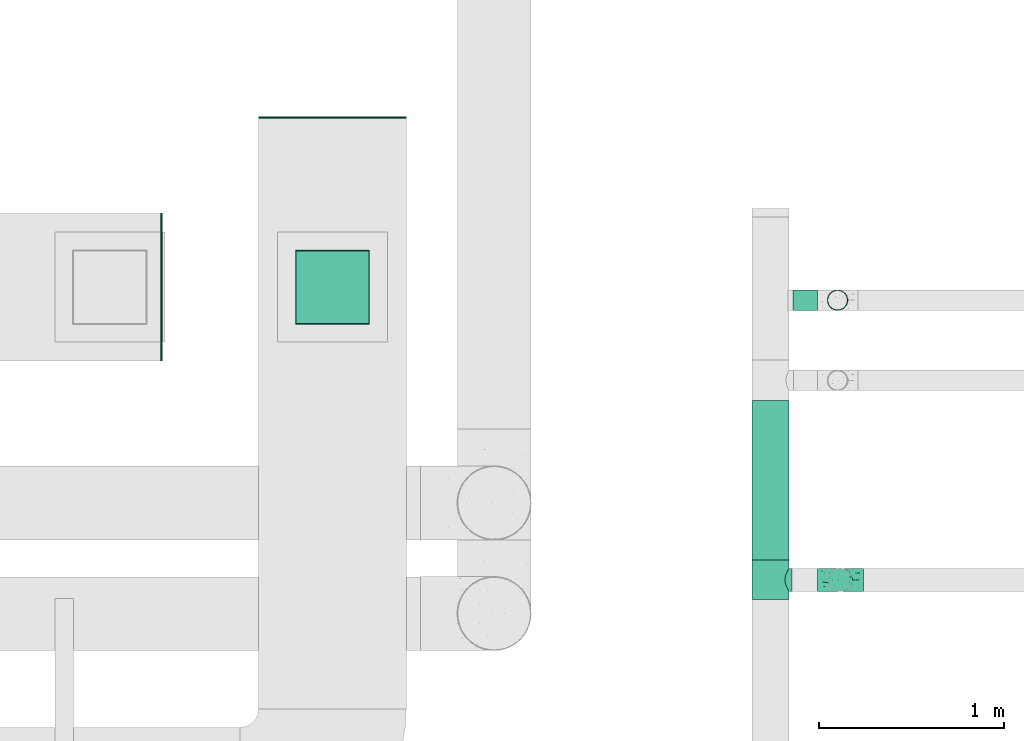
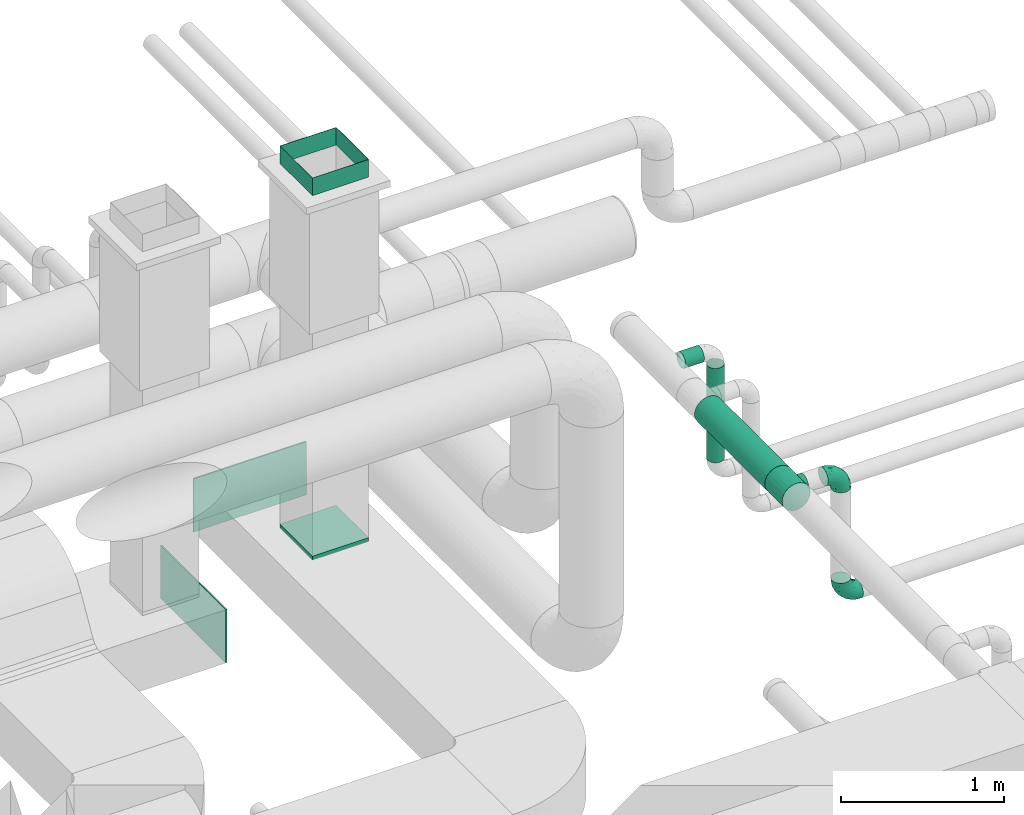
# One storey, part 65 of 91: 6 flow fittings, 4 flow segments.
"""IFC2X3 building model written with IfcOpenShell, lengths in millimetres."""

from ifc_helpers import new_model, entity, si_unit, converted_unit, derived_unit, direction, frame, origin_with_axes, origin_2d_with_axis, place, context, subcontext, project, spatial, hollow_rectangle, hollow_circle, extrude, open_shell, surface_model, source, transform, mapped, material, layer, layer_set, layer_usage, type_object, element, save


model = new_model("IFC2X3")

# Units and contexts
model_context = context("Model", 3, precision=1e-05, world=origin_with_axes(), true_north=direction((0.0, 1.0)))
body_context = subcontext(model_context, "Body", "Model", "MODEL_VIEW")
ifc_project = project(units=[si_unit("AREAUNIT", "SQUARE_METRE"), si_unit("VOLUMEUNIT", "CUBIC_METRE", prefix="DECI"), si_unit("TIMEUNIT", "SECOND"), si_unit("THERMODYNAMICTEMPERATUREUNIT", "DEGREE_CELSIUS"), si_unit("PRESSUREUNIT", "PASCAL"), si_unit("MASSUNIT", "GRAM", prefix="KILO"), si_unit("LENGTHUNIT", "METRE", prefix="MILLI"), si_unit("POWERUNIT", "WATT"), si_unit("ELECTRICCURRENTUNIT", "AMPERE"), si_unit("ELECTRICVOLTAGEUNIT", "VOLT"), derived_unit("VOLUMETRICFLOWRATEUNIT", [(si_unit("VOLUMEUNIT", "CUBIC_METRE", prefix="DECI"), 1), (si_unit("TIMEUNIT", "SECOND"), -1)]), derived_unit("LINEARVELOCITYUNIT", [(si_unit("LENGTHUNIT", "METRE"), 1), (si_unit("TIMEUNIT", "SECOND"), -1)]), derived_unit("MASSDENSITYUNIT", [(si_unit("MASSUNIT", "GRAM", prefix="KILO"), 1), (si_unit("VOLUMEUNIT", "CUBIC_METRE"), -1)]), converted_unit("PLANEANGLEUNIT", "DEGREE", entity("IfcRatioMeasure", 0.01745), si_unit("PLANEANGLEUNIT", "RADIAN"), dimensions=[0, 0, 0, 0, 0, 0, 0])], contexts=[model_context])

# Site, building, storey
site_placement = place(None, origin_with_axes())
site = spatial("IfcSite", under=ifc_project, at=site_placement, CompositionType="ELEMENT")
building_placement = place(site_placement, origin_with_axes())
building = spatial("IfcBuilding", under=site, at=building_placement, Name="mc-building", CompositionType="ELEMENT")
storey_placement = place(building_placement, frame((0.0, 0.0, 8700.0), z_axis=(0.0, 0.0, 1.0), x_axis=(1.0, 0.0, 0.0)))
storey = spatial("IfcBuildingStorey", under=building, at=storey_placement, CompositionType="ELEMENT", Elevation=8700.0)

# Flow fittings
duct_fitting_type_1 = type_object("IfcDuctFittingType", PredefinedType="JUNCTION")
shared_shape_1 = source(origin_with_axes(), body_context, "Body", "SurfaceModel", [
    surface_model("IfcShellBasedSurfaceModel", [(0.0, -115.0, -62.5), (16.17619, -115.0, -60.37037), (-16.17619, -115.0, -60.37037), (-60.37037, -115.0, 16.17619), (-31.25, -115.0, -54.12659), (-44.19417, -115.0, -44.19417), (-54.12659, -115.0, -31.25), (62.5, -115.0, 0.0), (60.37037, -115.0, 16.17619), (44.19417, -115.0, -44.19417), (31.25, -115.0, -54.12659), (60.37037, -115.0, -16.17619), (54.12659, -115.0, -31.25), (-60.37037, -115.0, -16.17619), (-54.12659, -115.0, 31.25), (-44.19417, -115.0, 44.19417), (-31.25, -115.0, 54.12659), (-16.17619, -115.0, 60.37037), (16.17619, -115.0, 60.37037), (54.12659, -115.0, 31.25), (44.19417, -115.0, 44.19417), (31.25, -115.0, 54.12659), (0.0, -115.0, 62.5), (-62.5, -115.0, 0.0), (0.0, -78.06248, 62.5), (-12.50928, -79.05841, 61.23535), (-24.28343, -81.75228, 57.58963), (-34.88436, -85.50245, 51.85876), (-44.09526, -89.65568, 44.29287), (-51.73336, -93.64876, 35.07007), (-57.55016, -96.98335, 24.37682), (-61.23402, -99.21368, 12.5158), (-62.5, -100.0, 0.0), (-61.23126, -99.21198, -12.5293), (-57.54468, -96.9801, -24.38976), (-51.72588, -93.64463, -35.0811), (-44.08702, -89.65163, -44.30107), (-34.87655, -85.49926, -51.86401), (-24.27625, -81.75015, -57.59265), (-12.50125, -79.05714, -61.23699), (0.0, -78.06248, -62.5), (12.50928, -79.05841, -61.23535), (24.28343, -81.75228, -57.58963), (34.88436, -85.50245, -51.85876), (44.09526, -89.65568, -44.29287), (51.73336, -93.64876, -35.07007), (57.55016, -96.98335, -24.37682), (61.23402, -99.21368, -12.5158), (62.5, -100.0, 0.0), (61.23402, -99.21368, 12.5158), (57.55016, -96.98335, 24.37682), (51.73336, -93.64876, 35.07007), (44.09526, -89.65568, 44.29287), (34.88436, -85.50245, 51.85876), (24.28343, -81.75228, 57.58963), (12.50928, -79.05841, 61.23535), (-107.5, 0.0, -100.0), (-107.5, -25.8819, -96.59259), (-107.5, 25.8819, -96.59259), (-107.5, 96.59259, 25.8819), (-107.5, 50.0, -86.60254), (-107.5, 86.60254, -50.0), (-107.5, 70.71068, -70.71068), (-107.5, -100.0, 0.0), (-107.5, -96.59259, 25.8819), (-107.5, -70.71068, -70.71068), (-107.5, -50.0, -86.60254), (-107.5, -96.59259, -25.8819), (-107.5, -86.60254, -50.0), (-107.5, 96.59259, -25.8819), (-107.5, 86.60254, 50.0), (-107.5, 70.71068, 70.71068), (-107.5, 50.0, 86.60254), (-107.5, 25.8819, 96.59259), (-107.5, 0.0, 100.0), (-107.5, -86.60254, 50.0), (-107.5, -70.71068, 70.71068), (-107.5, -25.8819, 96.59259), (-107.5, -50.0, 86.60254), (-107.5, 100.0, 0.0), (107.5, 25.8819, -96.59259), (107.5, 100.0, 0.0), (107.5, 0.0, -100.0), (107.5, 50.0, -86.60254), (107.5, 70.71068, -70.71068), (107.5, 86.60254, -50.0), (107.5, -70.71068, -70.71068), (107.5, -96.59259, 25.8819), (107.5, -50.0, -86.60254), (107.5, -25.8819, -96.59259), (107.5, -86.60254, -50.0), (107.5, -96.59259, -25.8819), (107.5, -100.0, 0.0), (107.5, 96.59259, -25.8819), (107.5, 96.59259, 25.8819), (107.5, 86.60254, 50.0), (107.5, 70.71068, 70.71068), (107.5, 25.8819, 96.59259), (107.5, 50.0, 86.60254), (107.5, -25.8819, 96.59259), (107.5, -86.60254, 50.0), (107.5, -70.71068, 70.71068), (107.5, -50.0, 86.60254), (107.5, 0.0, 100.0), (107.5, -91.59756, -37.94095), (-107.5, -98.29629, -12.94095), (-107.5, -91.59756, -37.94095), (107.5, -98.29629, -12.94095), (107.5, -98.29629, 12.94095), (107.5, -91.59756, 37.94095), (-107.5, -98.29629, 12.94095), (-107.5, -91.59756, 37.94095)], [open_shell([[[0, 1, 2]], [[2, 3, 4]], [[5, 3, 6]], [[4, 3, 5]], [[2, 7, 8]], [[9, 7, 10]], [[1, 10, 7]], [[11, 7, 12]], [[9, 12, 7]], [[7, 2, 1]], [[13, 6, 3]], [[2, 14, 3]], [[2, 15, 14]], [[16, 2, 17]], [[16, 15, 2]], [[17, 2, 18]], [[19, 20, 2]], [[19, 2, 8]], [[20, 21, 2]], [[2, 21, 18]], [[18, 22, 17]], [[23, 13, 3]], [[22, 24, 25]], [[17, 25, 26]], [[16, 26, 27]], [[22, 25, 17]], [[15, 27, 28]], [[16, 17, 26]], [[27, 15, 16]], [[29, 30, 14]], [[31, 32, 23]], [[30, 31, 3]], [[15, 29, 14]], [[3, 14, 30]], [[23, 3, 31]], [[29, 15, 28]], [[32, 33, 23]], [[34, 35, 6]], [[33, 34, 13]], [[23, 33, 13]], [[6, 13, 34]], [[5, 6, 35]], [[35, 36, 5]], [[4, 37, 38]], [[38, 39, 2]], [[40, 0, 39]], [[37, 5, 36]], [[37, 4, 5]], [[4, 38, 2]], [[39, 0, 2]], [[0, 40, 41]], [[1, 41, 42]], [[10, 42, 43]], [[0, 41, 1]], [[9, 43, 44]], [[10, 1, 42]], [[43, 9, 10]], [[45, 46, 12]], [[47, 48, 7]], [[46, 47, 11]], [[9, 45, 12]], [[11, 12, 46]], [[7, 11, 47]], [[45, 9, 44]], [[48, 49, 7]], [[50, 51, 19]], [[49, 50, 8]], [[7, 49, 8]], [[19, 8, 50]], [[20, 19, 51]], [[51, 52, 20]], [[21, 53, 54]], [[54, 55, 18]], [[24, 22, 55]], [[53, 20, 52]], [[53, 21, 20]], [[21, 54, 18]], [[55, 22, 18]], [[56, 57, 58]], [[58, 59, 60]], [[61, 62, 59]], [[59, 62, 60]], [[58, 63, 64]], [[65, 63, 66]], [[58, 57, 66]], [[67, 63, 68]], [[65, 68, 63]], [[66, 63, 58]], [[69, 61, 59]], [[70, 59, 58]], [[58, 71, 70]], [[72, 58, 73]], [[72, 71, 58]], [[74, 73, 58]], [[75, 76, 58]], [[58, 64, 75]], [[77, 74, 78]], [[58, 76, 78]], [[78, 74, 58]], [[79, 69, 59]], [[80, 81, 82]], [[83, 81, 80]], [[81, 84, 85]], [[83, 84, 81]], [[86, 82, 87]], [[82, 88, 89]], [[82, 86, 88]], [[90, 87, 91]], [[87, 90, 86]], [[92, 91, 87]], [[93, 81, 85]], [[94, 95, 82]], [[95, 96, 82]], [[97, 82, 98]], [[82, 96, 98]], [[99, 82, 97]], [[82, 100, 87]], [[101, 100, 82]], [[101, 82, 102]], [[99, 102, 82]], [[97, 103, 99]], [[82, 81, 94]], [[73, 103, 97]], [[72, 97, 98]], [[74, 103, 73]], [[73, 97, 72]], [[98, 71, 72]], [[98, 96, 71]], [[59, 95, 94]], [[79, 94, 81]], [[96, 70, 71]], [[96, 95, 70]], [[70, 95, 59]], [[94, 79, 59]], [[93, 85, 61]], [[81, 93, 69]], [[69, 79, 81]], [[61, 69, 93]], [[85, 62, 61]], [[85, 84, 62]], [[58, 83, 80]], [[56, 80, 82]], [[84, 60, 62]], [[84, 83, 60]], [[60, 83, 58]], [[80, 56, 58]], [[89, 57, 82]], [[88, 66, 89]], [[42, 90, 43]], [[90, 42, 86]], [[44, 104, 45]], [[42, 41, 86]], [[88, 86, 65]], [[86, 41, 40]], [[57, 89, 66]], [[65, 66, 88]], [[57, 56, 82]], [[40, 39, 65]], [[33, 63, 105]], [[65, 38, 68]], [[35, 67, 106]], [[46, 107, 47]], [[39, 38, 65]], [[65, 86, 40]], [[68, 38, 37]], [[104, 91, 45]], [[44, 90, 104]], [[91, 46, 45]], [[92, 48, 47]], [[91, 107, 46]], [[47, 107, 92]], [[35, 106, 36]], [[68, 36, 106]], [[35, 34, 67]], [[68, 37, 36]], [[105, 67, 34]], [[32, 63, 33]], [[105, 34, 33]], [[43, 90, 44]], [[48, 92, 49]], [[108, 87, 50]], [[50, 87, 51]], [[50, 49, 108]], [[52, 51, 109]], [[109, 100, 52]], [[63, 31, 110]], [[63, 32, 31]], [[30, 64, 110]], [[28, 75, 111]], [[111, 64, 29]], [[75, 28, 27]], [[29, 64, 30]], [[53, 100, 54]], [[51, 87, 109]], [[101, 55, 54]], [[54, 100, 101]], [[30, 110, 31]], [[102, 99, 77]], [[78, 101, 102]], [[55, 101, 24]], [[74, 99, 103]], [[25, 24, 76]], [[49, 92, 108]], [[26, 76, 75]], [[25, 76, 26]], [[28, 111, 29]], [[24, 101, 76]], [[101, 78, 76]], [[77, 78, 102]], [[99, 74, 77]], [[26, 75, 27]], [[53, 52, 100]]])]),
])
flow_fitting_1_placement = place(storey_placement, frame((33364.76981, 6304.03427, 1344.0), z_axis=(0.0, 0.0, 1.0), x_axis=(0.0, 1.0, 0.0)))
element("IfcFlowFitting", 1, at=flow_fitting_1_placement, inside=storey, type_object=duct_fitting_type_1, context=body_context, shape_type="MappedRepresentation", body=[
    mapped(shared_shape_1, transform((0.0, 0.0, 0.0), scale=1.0)),
])
duct_fitting_type_2 = type_object("IfcDuctFittingType", Name="BU", PredefinedType="BEND")
shared_shape_2 = source(origin_with_axes(), body_context, "Body", "SurfaceModel", [
    surface_model("IfcShellBasedSurfaceModel", [(-125.0, 0.0, -62.5), (-125.0, -16.17619, -60.37037), (-125.0, 16.17619, -60.37037), (-125.0, 60.37037, 16.17619), (-125.0, 31.25, -54.12659), (-125.0, 54.12659, -31.25), (-125.0, 44.19417, -44.19417), (-125.0, -62.5, 0.0), (-125.0, -60.37037, 16.17619), (-125.0, -44.19417, -44.19417), (-125.0, -31.25, -54.12659), (-125.0, -60.37037, -16.17619), (-125.0, -54.12659, -31.25), (-125.0, 60.37037, -16.17619), (-125.0, 54.12659, 31.25), (-125.0, 44.19417, 44.19417), (-125.0, 16.17619, 60.37037), (-125.0, 31.25, 54.12659), (-125.0, -16.17619, 60.37037), (-125.0, -54.12659, 31.25), (-125.0, -44.19417, 44.19417), (-125.0, -31.25, 54.12659), (-125.0, 0.0, 62.5), (-125.0, 62.5, 0.0), (-16.17619, 125.0, -60.37037), (-62.5, 125.0, 0.0), (0.0, 125.0, -62.5), (-31.25, 125.0, -54.12659), (-44.19417, 125.0, -44.19417), (-54.12659, 125.0, -31.25), (44.19417, 125.0, -44.19417), (60.37037, 125.0, 16.17619), (31.25, 125.0, -54.12659), (16.17619, 125.0, -60.37037), (54.12659, 125.0, -31.25), (60.37037, 125.0, -16.17619), (62.5, 125.0, 0.0), (-60.37037, 125.0, -16.17619), (-60.37037, 125.0, 16.17619), (-54.12659, 125.0, 31.25), (-44.19417, 125.0, 44.19417), (-31.25, 125.0, 54.12659), (0.0, 125.0, 62.5), (-16.17619, 125.0, 60.37037), (54.12659, 125.0, 31.25), (44.19417, 125.0, 44.19417), (31.25, 125.0, 54.12659), (16.17619, 125.0, 60.37037), (-72.97423, 55.32904, 49.58459), (-87.09148, 43.38651, 51.77259), (-68.69218, 37.01083, 59.02974), (-86.37288, 6.11794, 62.5), (-102.44946, 13.57266, 61.46748), (-89.31796, 30.42505, 57.74247), (-79.75876, 21.08139, 61.40263), (-85.85709, 61.60432, 36.83247), (-105.99571, 52.01835, 38.04759), (-109.23107, 25.15527, 57.74247), (-23.87288, 51.52684, 62.5), (-20.86657, 80.09577, 61.41459), (-36.41116, 67.77294, 59.36871), (-72.59833, 84.97566, 20.44471), (-84.84527, 71.68644, 22.63776), (-72.28039, 75.08953, 34.06229), (-113.17841, 59.9112, 21.05599), (-105.80839, 64.31191, 11.93589), (-111.60883, 65.16367, 0.0), (-60.71426, 105.22832, 23.91771), (-100.62332, 62.31546, 23.91771), (-13.4791, 102.54506, 61.48083), (-6.11794, 86.37288, 62.5), (-65.16367, 111.60883, 0.0), (-64.37068, 105.82697, 11.61464), (-51.52684, 23.87288, 62.5), (-50.69134, 50.69135, 59.24335), (-105.32369, 40.3031, 49.58458), (-25.28712, 108.41778, 57.74247), (-40.88389, 102.97269, 49.58458), (-49.66967, 79.07581, 50.53579), (-30.95126, 87.95323, 57.74247), (-65.09409, 90.12761, 28.38341), (-66.67939, 95.80824, 18.23245), (-94.24179, 68.59274, 14.67936), (-56.68565, 61.95245, 53.66363), (-84.74719, 75.95181, 10.86071), (-51.54332, 107.92365, 38.04759), (-67.25753, 101.08228, 0.0), (-58.54205, 89.35136, 38.04759), (-74.03168, 90.94406, 0.0), (-64.15138, 70.52814, 45.04029), (-101.08228, 67.25753, 0.0), (-80.80582, 80.80582, 0.0), (-90.94406, 74.03168, 0.0), (-107.87602, 51.55441, -38.04759), (-105.81087, 64.31979, -11.89334), (-113.23859, 59.9943, -20.79563), (-102.50484, 41.0078, -49.58458), (-90.90834, 52.91787, -43.09941), (-86.37288, 6.11794, -62.5), (-82.6746, 22.37103, -60.91508), (-51.52684, 23.87288, -62.5), (-24.90859, 74.00088, -61.20337), (-6.11794, 86.37288, -62.5), (-23.87288, 51.52684, -62.5), (-40.24859, 105.55983, -49.58458), (-103.52624, 12.53143, -61.61172), (-52.01835, 105.9957, -38.04759), (-102.84629, 26.37525, -57.74247), (-80.60061, 37.86129, -56.26993), (-89.23788, 71.99576, -13.34087), (-28.31259, 95.51825, -57.74247), (-100.89706, 62.20969, -23.91771), (-79.09001, 65.16893, -38.04759), (-83.36843, 70.98492, -26.07025), (-72.14843, 76.80808, -32.35146), (-64.31191, 105.80839, -11.93589), (-62.31546, 100.62332, -23.91771), (-61.48499, 86.19979, -36.72576), (-65.63586, 35.3365, -60.01002), (-59.9112, 113.17841, -21.05599), (-14.35128, 101.66255, -61.35337), (-39.16846, 75.52412, -56.86737), (-49.98148, 49.98148, -59.57135), (-74.75599, 82.48123, -20.09995), (-79.93714, 49.60562, -50.24944), (-65.30683, 59.08485, -51.03937), (-69.00621, 93.51335, -14.6428), (-48.12403, 84.36987, -49.58459), (-65.05902, 72.16091, -43.27513), (-91.99255, 60.8749, -33.31849), (-74.30538, -22.05025, -54.52849), (-83.27732, -57.79898, 0.0), (-93.43528, -58.70511, -11.68929), (-65.26967, -50.32842, -16.71444), (20.96007, 31.53005, -39.63719), (36.17209, 58.4237, -38.31102), (29.66468, 29.66696, -26.32537), (-59.46467, 5.17337, -61.41841), (9.88584, 35.44281, -50.43749), (-6.21876, 6.21876, -45.37394), (1.26602, -1.26602, -32.1996), (5.97284, -5.97284, -16.71444), (-29.66696, -29.66468, -26.32537), (-5.17337, 59.46467, -61.41841), (-25.56296, 25.56296, -60.51531), (-85.76554, -12.75621, -59.78088), (48.55289, 56.98302, -11.64673), (57.71969, 88.32124, -11.85826), (57.79898, 83.27732, 0.0), (-8.09566, -21.5934, 0.0), (-43.6468, -43.93166, 0.0), (-26.3245, -32.97333, -12.3928), (-83.98915, -46.13442, -36.15679), (-66.40639, -30.82245, -46.75569), (-31.53004, -20.96006, -39.63719), (-52.51367, -36.89027, -34.10077), (12.75621, 85.76554, -59.78088), (4.48155, 49.92421, -57.42403), (37.53998, 99.49287, -48.41169), (22.05025, 74.30538, -54.52849), (-15.22434, 15.22435, -54.69384), (-49.9242, -4.48154, -57.42403), (51.83554, 76.17092, -22.12398), (46.66757, 86.70304, -36.28653), (-35.4428, -9.88583, -50.43749), (21.5934, 8.09566, 0.0), (43.93166, 43.6468, 0.0), (32.97333, 26.3245, -12.3928), (-99.49287, -37.53998, -48.41169), (30.82245, 66.40639, -46.75569), (-56.98302, -48.55289, 11.64673), (-88.32124, -57.71969, 11.85826), (50.32842, 65.26967, 16.71444), (-76.17092, -51.83554, 22.12398), (-5.17337, 59.46467, 61.41841), (12.75621, 85.76554, 59.78088), (-85.76554, -12.75621, 59.78088), (-49.9242, -4.48154, 57.42403), (-59.46467, 5.17337, 61.41841), (-26.3245, -32.97333, 12.3928), (-35.4428, -9.88583, 50.43749), (-31.53004, -20.96006, 39.63719), (-6.21876, 6.21876, 45.37394), (32.97333, 26.3245, 12.3928), (5.97284, -5.97284, 16.71444), (-99.49287, -37.53998, 48.41169), (-86.70304, -46.66757, 36.28653), (9.88584, 35.44281, 50.43749), (20.96007, 31.53005, 39.63719), (-15.22434, 15.22435, 54.69384), (4.48155, 49.92421, 57.42403), (-74.30538, -22.05025, 54.52849), (-25.56296, 25.56296, 60.51531), (37.53998, 99.49287, 48.41169), (46.13442, 83.98915, 36.15679), (29.66468, 29.66696, 26.32537), (-29.66696, -29.66468, 26.32537), (1.26602, -1.26602, 32.1996), (58.70511, 93.43528, 11.68929), (30.82245, 66.40639, 46.75569), (36.89027, 52.51367, 34.10076), (22.05025, 74.30538, 54.52849), (-58.42369, -36.17209, 38.31102), (-66.40639, -30.82245, 46.75569)], [open_shell([[[0, 1, 2]], [[2, 3, 4]], [[5, 6, 3]], [[4, 3, 6]], [[2, 7, 8]], [[9, 7, 10]], [[1, 10, 7]], [[11, 7, 12]], [[9, 12, 7]], [[7, 2, 1]], [[5, 3, 13]], [[14, 3, 2]], [[15, 14, 2]], [[2, 16, 17]], [[17, 15, 2]], [[2, 18, 16]], [[2, 8, 19]], [[2, 19, 20]], [[20, 21, 2]], [[18, 2, 21]], [[18, 22, 16]], [[23, 13, 3]], [[24, 25, 26]], [[27, 25, 24]], [[25, 28, 29]], [[28, 25, 27]], [[30, 26, 31]], [[26, 32, 33]], [[26, 30, 32]], [[30, 31, 34]], [[34, 31, 35]], [[31, 36, 35]], [[29, 37, 25]], [[38, 39, 26]], [[39, 40, 26]], [[26, 41, 42]], [[41, 26, 40]], [[41, 43, 42]], [[44, 31, 26]], [[45, 44, 26]], [[26, 46, 45]], [[47, 46, 26]], [[47, 26, 42]], [[25, 38, 26]], [[48, 49, 50]], [[22, 51, 52]], [[53, 54, 50]], [[55, 56, 49]], [[56, 14, 15]], [[16, 57, 17]], [[58, 59, 60]], [[61, 62, 63]], [[3, 64, 65]], [[53, 52, 54]], [[3, 65, 66]], [[67, 39, 38]], [[56, 68, 64]], [[65, 64, 68]], [[69, 59, 70]], [[38, 71, 72]], [[73, 58, 74]], [[75, 49, 56]], [[76, 69, 43]], [[53, 57, 52]], [[77, 78, 79]], [[41, 76, 43]], [[43, 69, 42]], [[55, 68, 56]], [[15, 17, 75]], [[76, 77, 79]], [[80, 67, 81]], [[62, 82, 68]], [[60, 78, 83]], [[62, 84, 82]], [[85, 77, 40]], [[81, 67, 72]], [[86, 72, 71]], [[87, 85, 67]], [[61, 81, 88]], [[77, 41, 40]], [[78, 77, 87]], [[15, 75, 56]], [[83, 89, 48]], [[85, 40, 39]], [[62, 68, 55]], [[89, 87, 63]], [[83, 48, 50]], [[57, 75, 17]], [[49, 75, 53]], [[67, 85, 39]], [[87, 77, 85]], [[63, 62, 55]], [[89, 55, 48]], [[80, 63, 87]], [[66, 65, 90]], [[66, 23, 3]], [[84, 91, 92]], [[92, 90, 82]], [[65, 82, 90]], [[61, 84, 62]], [[92, 82, 84]], [[68, 82, 65]], [[3, 14, 64]], [[56, 64, 14]], [[38, 25, 71]], [[81, 72, 86]], [[38, 72, 67]], [[91, 61, 88]], [[80, 81, 61]], [[63, 80, 61]], [[67, 80, 87]], [[77, 76, 41]], [[79, 59, 69]], [[79, 69, 76]], [[42, 69, 70]], [[60, 59, 79]], [[58, 70, 59]], [[78, 60, 79]], [[58, 60, 74]], [[52, 57, 16]], [[75, 57, 53]], [[22, 52, 16]], [[52, 51, 54]], [[51, 73, 54]], [[50, 73, 74]], [[73, 50, 54]], [[50, 74, 83]], [[60, 83, 74]], [[89, 83, 78]], [[87, 89, 78]], [[55, 89, 63]], [[50, 49, 53]], [[55, 49, 48]], [[81, 86, 88]], [[91, 84, 61]], [[6, 5, 93]], [[90, 94, 66]], [[13, 94, 95]], [[96, 93, 97]], [[98, 99, 100]], [[96, 4, 6]], [[101, 102, 103]], [[28, 27, 104]], [[2, 105, 0]], [[104, 106, 28]], [[99, 105, 107]], [[108, 107, 96]], [[90, 109, 94]], [[107, 2, 4]], [[13, 66, 94]], [[27, 24, 110]], [[109, 111, 94]], [[112, 113, 114]], [[37, 115, 71]], [[116, 106, 117]], [[99, 118, 100]], [[116, 115, 119]], [[37, 119, 115]], [[24, 120, 110]], [[121, 110, 101]], [[119, 106, 116]], [[101, 110, 120]], [[122, 103, 100]], [[117, 123, 116]], [[124, 125, 108]], [[115, 116, 126]], [[106, 29, 28]], [[26, 102, 120]], [[127, 104, 110]], [[97, 124, 96]], [[125, 122, 118]], [[128, 127, 125]], [[96, 6, 93]], [[115, 126, 86]], [[117, 106, 127]], [[111, 113, 129]], [[95, 93, 5]], [[97, 129, 112]], [[110, 104, 27]], [[106, 104, 127]], [[96, 107, 4]], [[99, 107, 108]], [[99, 108, 118]], [[105, 99, 98]], [[112, 114, 128]], [[121, 125, 127]], [[13, 23, 66]], [[109, 90, 92]], [[94, 111, 95]], [[91, 123, 109]], [[129, 113, 112]], [[93, 95, 111]], [[5, 13, 95]], [[71, 115, 86]], [[71, 25, 37]], [[123, 91, 88]], [[126, 116, 123]], [[123, 88, 126]], [[86, 126, 88]], [[37, 29, 119]], [[106, 119, 29]], [[129, 93, 111]], [[124, 112, 125]], [[0, 105, 98]], [[107, 105, 2]], [[125, 118, 108]], [[100, 118, 122]], [[93, 129, 97]], [[113, 111, 109]], [[109, 123, 113]], [[114, 123, 117]], [[123, 114, 113]], [[128, 114, 117]], [[127, 128, 117]], [[112, 128, 125]], [[103, 122, 101]], [[110, 121, 127]], [[101, 122, 121]], [[125, 121, 122]], [[26, 120, 24]], [[101, 120, 102]], [[96, 124, 108]], [[92, 91, 109]], [[112, 124, 97]], [[10, 1, 130]], [[131, 132, 133]], [[134, 135, 136]], [[98, 100, 137]], [[138, 134, 139]], [[140, 141, 142]], [[143, 144, 103]], [[98, 145, 0]], [[146, 147, 148]], [[149, 150, 151]], [[7, 11, 132]], [[133, 12, 152]], [[153, 154, 155]], [[152, 12, 9]], [[156, 157, 143]], [[142, 151, 133]], [[155, 133, 152]], [[158, 159, 32]], [[136, 141, 140]], [[137, 145, 98]], [[103, 144, 100]], [[133, 132, 12]], [[160, 161, 144]], [[137, 144, 161]], [[160, 144, 157]], [[156, 26, 33]], [[130, 1, 145]], [[34, 162, 163]], [[164, 139, 154]], [[30, 158, 32]], [[160, 138, 139]], [[163, 30, 34]], [[156, 159, 157]], [[149, 141, 165]], [[146, 166, 167]], [[168, 9, 10]], [[36, 148, 147]], [[9, 168, 152]], [[150, 131, 133]], [[166, 146, 148]], [[166, 165, 167]], [[141, 136, 167]], [[160, 164, 161]], [[143, 103, 102]], [[151, 141, 149]], [[35, 162, 34]], [[135, 162, 136]], [[158, 163, 169]], [[144, 137, 100]], [[145, 137, 161]], [[145, 161, 130]], [[145, 1, 0]], [[102, 26, 156]], [[144, 143, 157]], [[102, 156, 143]], [[159, 33, 32]], [[141, 167, 165]], [[146, 136, 162]], [[133, 151, 150]], [[141, 151, 142]], [[164, 130, 161]], [[130, 153, 168]], [[159, 156, 33]], [[138, 159, 169]], [[138, 160, 157]], [[164, 160, 139]], [[154, 140, 142]], [[134, 140, 139]], [[159, 138, 157]], [[134, 136, 140]], [[138, 169, 134]], [[135, 134, 169]], [[139, 140, 154]], [[130, 164, 153]], [[155, 154, 142]], [[153, 164, 154]], [[136, 146, 167]], [[146, 162, 147]], [[162, 35, 147]], [[36, 147, 35]], [[130, 168, 10]], [[152, 168, 153]], [[163, 158, 30]], [[159, 158, 169]], [[7, 132, 131]], [[12, 132, 11]], [[169, 163, 135]], [[135, 163, 162]], [[133, 155, 142]], [[153, 155, 152]], [[150, 170, 131]], [[171, 7, 131]], [[166, 148, 172]], [[8, 173, 19]], [[174, 175, 70]], [[176, 177, 178]], [[149, 179, 150]], [[170, 150, 179]], [[180, 181, 182]], [[165, 183, 184]], [[20, 185, 21]], [[20, 19, 186]], [[187, 182, 188]], [[189, 187, 190]], [[185, 191, 21]], [[22, 18, 176]], [[190, 192, 189]], [[189, 180, 182]], [[178, 73, 51]], [[19, 173, 186]], [[149, 165, 184]], [[45, 193, 194]], [[191, 177, 176]], [[165, 166, 183]], [[195, 183, 172]], [[196, 184, 197]], [[194, 44, 45]], [[198, 36, 31]], [[199, 188, 200]], [[172, 198, 44]], [[193, 45, 46]], [[194, 200, 172]], [[175, 42, 70]], [[192, 58, 73]], [[170, 171, 131]], [[189, 192, 177]], [[70, 58, 174]], [[190, 174, 192]], [[179, 184, 196]], [[197, 184, 195]], [[47, 201, 46]], [[181, 202, 196]], [[148, 198, 172]], [[201, 47, 175]], [[172, 44, 194]], [[178, 192, 73]], [[202, 173, 196]], [[185, 186, 203]], [[192, 174, 58]], [[175, 174, 190]], [[175, 190, 201]], [[175, 47, 42]], [[51, 22, 176]], [[192, 178, 177]], [[51, 176, 178]], [[191, 18, 21]], [[184, 179, 149]], [[170, 196, 173]], [[172, 183, 166]], [[184, 183, 195]], [[187, 201, 190]], [[201, 199, 193]], [[191, 176, 18]], [[180, 191, 203]], [[180, 189, 177]], [[187, 189, 182]], [[188, 197, 195]], [[181, 197, 182]], [[191, 180, 177]], [[181, 196, 197]], [[180, 203, 181]], [[202, 181, 203]], [[182, 197, 188]], [[201, 187, 199]], [[200, 188, 195]], [[199, 187, 188]], [[196, 170, 179]], [[170, 173, 171]], [[173, 8, 171]], [[7, 171, 8]], [[201, 193, 46]], [[194, 193, 199]], [[186, 185, 20]], [[191, 185, 203]], [[36, 198, 148]], [[44, 198, 31]], [[203, 186, 202]], [[202, 186, 173]], [[172, 200, 195]], [[199, 200, 194]]])]),
])
for number, where, z_axis, x_axis, name in (
    (2, (33742.76981, 6304.03427, 1344.0), (0.0, -1.0, 0.0), (0.0, 0.0, 1.0), "BU"),
    (3, (33742.76981, 6304.03427, 415.0), (0.0, 1.0, 0.0), (-1.0, 0.0, 0.0), "BU"),
):
    element("IfcFlowFitting", number, at=place(storey_placement, frame(where, z_axis=z_axis, x_axis=x_axis)), inside=storey, type_object=duct_fitting_type_2, Name=name, context=body_context, shape_type="MappedRepresentation", body=[
        mapped(shared_shape_2, transform((0.0, 0.0, 0.0), scale=1.0)),
    ])

# Flow segment
ifc_material_1 = material(Name="FZ1")
ifc_layer_1 = layer(ifc_material_1, 0.0)
ifc_layer_set_1 = layer_set([ifc_layer_1], Name="FZ1")
ifc_layer_usage_1 = layer_usage(ifc_layer_set_1, "AXIS1", "POSITIVE", 0.0)
duct_segment_type_1 = type_object("IfcDuctSegmentType", PredefinedType="RIGIDSEGMENT")
shared_shape_3 = source(origin_with_axes(), body_context, "Body", "SweptSolid", [
    extrude(hollow_circle(Radius=55.0, WallThickness=2.0, at=origin_2d_with_axis()), frame((0.0, 0.0, 0.0), z_axis=(1.0, 0.0, 0.0), x_axis=(0.0, 1.0, 0.0)), (0.0, 0.0, 1.0), 709.0),
])
flow_segment_1_placement = place(storey_placement, frame((33727.76981, 7819.73852, 1234.0), z_axis=(0.0, 1.0, 0.0), x_axis=(0.0, 0.0, -1.0)))
element("IfcFlowSegment", 4, at=flow_segment_1_placement, inside=storey, type_object=duct_segment_type_1, material=ifc_layer_usage_1, context=body_context, shape_type="MappedRepresentation", body=[
    mapped(shared_shape_3, transform((0.0, 0.0, 0.0), scale=1.0)),
])

# Flow fittings
duct_fitting_type_3 = type_object("IfcDuctFittingType", Name="R", PredefinedType="OBSTRUCTION")
shared_shape_4 = source(origin_with_axes(), body_context, "Body", "SurfaceModel", [
    surface_model("IfcShellBasedSurfaceModel", [(0.0, 400.0, 200.0), (0.0, 400.0, -200.0), (0.0, -400.0, -200.0), (0.0, -400.0, 200.0), (10.0, -400.0, -200.0), (10.0, 400.0, -200.0), (10.0, -400.0, 200.0), (10.0, 400.0, 200.0)], [open_shell([[[0, 1, 2]], [[2, 3, 0]], [[4, 5, 6]], [[7, 6, 5]], [[1, 0, 7]], [[7, 5, 1]], [[2, 1, 5]], [[5, 4, 2]], [[3, 2, 4]], [[4, 6, 3]], [[0, 3, 7]], [[6, 7, 3]]])]),
])
for number, where, z_axis, x_axis, name in (
    (5, (30990.3445, 8804.45799, 668.0), (0.0, 0.0, 1.0), (0.0, 1.0, 0.0), "R"),
    (6, (30058.6989, 7890.34565, 668.0), (0.0, 0.0, 1.0), (1.0, 0.0, 0.0), "R"),
):
    element("IfcFlowFitting", number, at=place(storey_placement, frame(where, z_axis=z_axis, x_axis=x_axis)), inside=storey, type_object=duct_fitting_type_3, Name=name, context=body_context, shape_type="MappedRepresentation", body=[
        mapped(shared_shape_4, transform((0.0, 0.0, 0.0), scale=1.0)),
    ])

# Flow segment
duct_segment_type_2 = type_object("IfcDuctSegmentType", Name="Safe", PredefinedType="RIGIDSEGMENT")
shared_shape_5 = source(origin_with_axes(), body_context, "Body", "SweptSolid", [
    extrude(hollow_circle(Radius=100.0, WallThickness=2.0, at=origin_2d_with_axis()), frame((0.0, 0.0, 0.0), z_axis=(1.0, 0.0, 0.0), x_axis=(0.0, 1.0, 0.0)), (0.0, 0.0, 1.0), 863.4),
])
flow_segment_2_placement = place(storey_placement, frame((33364.76981, 6411.53427, 1344.0), z_axis=(0.0, 0.0, 1.0), x_axis=(0.0, 1.0, 0.0)))
element("IfcFlowSegment", 7, at=flow_segment_2_placement, inside=storey, type_object=duct_segment_type_2, material=ifc_layer_usage_1, Name="Safe", context=body_context, shape_type="MappedRepresentation", body=[
    mapped(shared_shape_5, transform((0.0, 0.0, 0.0), scale=1.0)),
])

# Flow fitting
duct_fitting_type_4 = type_object("IfcDuctFittingType", Name="RR", PredefinedType="CONNECTOR")
shared_shape_6 = source(origin_with_axes(), body_context, "Body", "SurfaceModel", [
    surface_model("IfcShellBasedSurfaceModel", [(-6.096, 200.0, -200.0), (-6.096, -200.0, -200.0), (-6.096, -200.0, 200.0), (-6.096, 200.0, 200.0), (25.0, -200.0, -200.0), (25.0, -200.0, 200.0), (25.0, 200.0, -200.0), (25.0, 200.0, 200.0)], [open_shell([[[0, 1, 2]], [[2, 3, 0]], [[4, 2, 1]], [[2, 4, 5]], [[6, 1, 0]], [[1, 6, 4]], [[6, 0, 3]], [[3, 7, 6]], [[7, 3, 2]], [[2, 5, 7]], [[7, 5, 4]], [[4, 6, 7]]])]),
])
flow_fitting_2_placement = place(storey_placement, frame((30990.3445, 7890.34565, 868.0), z_axis=(0.0, -1.0, 0.0), x_axis=(0.0, 0.0, 1.0)))
element("IfcFlowFitting", 8, at=flow_fitting_2_placement, inside=storey, type_object=duct_fitting_type_4, Name="RR", context=body_context, shape_type="MappedRepresentation", body=[
    mapped(shared_shape_6, transform((0.0, 0.0, 0.0), scale=1.0)),
])

# Flow segments
ifc_material_2 = material(Name="1")
ifc_layer_2 = layer(ifc_material_2, 0.0)
ifc_layer_set_2 = layer_set([ifc_layer_2], Name="1")
ifc_layer_usage_2 = layer_usage(ifc_layer_set_2, "AXIS1", "POSITIVE", 0.0)
duct_segment_type_3 = type_object("IfcDuctSegmentType", PredefinedType="RIGIDSEGMENT")
shared_shape_7 = source(origin_with_axes(), body_context, "Body", "SweptSolid", [
    extrude(hollow_rectangle(XDim=400.0, YDim=400.0, WallThickness=2.0, at=origin_2d_with_axis()), frame((0.0, 0.0, 0.0), z_axis=(1.0, 0.0, 0.0), x_axis=(0.0, 1.0, 0.0)), (0.0, 0.0, 1.0), 132.0),
])
flow_segment_3_placement = place(storey_placement, frame((30990.3445, 7890.34565, 3600.0), z_axis=(0.0, -1.0, 0.0), x_axis=(0.0, 0.0, 1.0)))
element("IfcFlowSegment", 9, at=flow_segment_3_placement, inside=storey, type_object=duct_segment_type_3, material=ifc_layer_usage_2, context=body_context, shape_type="MappedRepresentation", body=[
    mapped(shared_shape_7, transform((0.0, 0.0, 0.0), scale=1.0)),
])
shared_shape_8 = source(origin_with_axes(), body_context, "Body", "SweptSolid", [
    extrude(hollow_circle(Radius=55.0, WallThickness=2.0, at=origin_2d_with_axis()), frame((0.0, 0.0, 0.0), z_axis=(1.0, 0.0, 0.0), x_axis=(0.0, 1.0, 0.0)), (0.0, 0.0, 1.0), 133.0),
])
flow_segment_4_placement = place(storey_placement, frame((33484.76981, 7819.73852, 1344.0), z_axis=(0.0, 0.0, 1.0), x_axis=(1.0, 0.0, 0.0)))
element("IfcFlowSegment", 10, at=flow_segment_4_placement, inside=storey, type_object=duct_segment_type_1, material=ifc_layer_usage_1, context=body_context, shape_type="MappedRepresentation", body=[
    mapped(shared_shape_8, transform((0.0, 0.0, 0.0), scale=1.0)),
])

save(model, "model.ifc")
